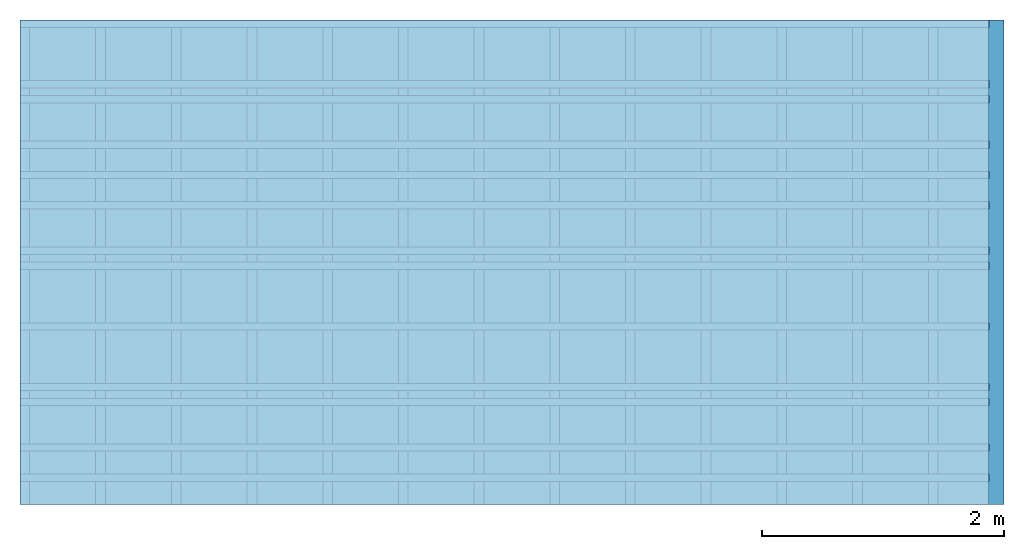
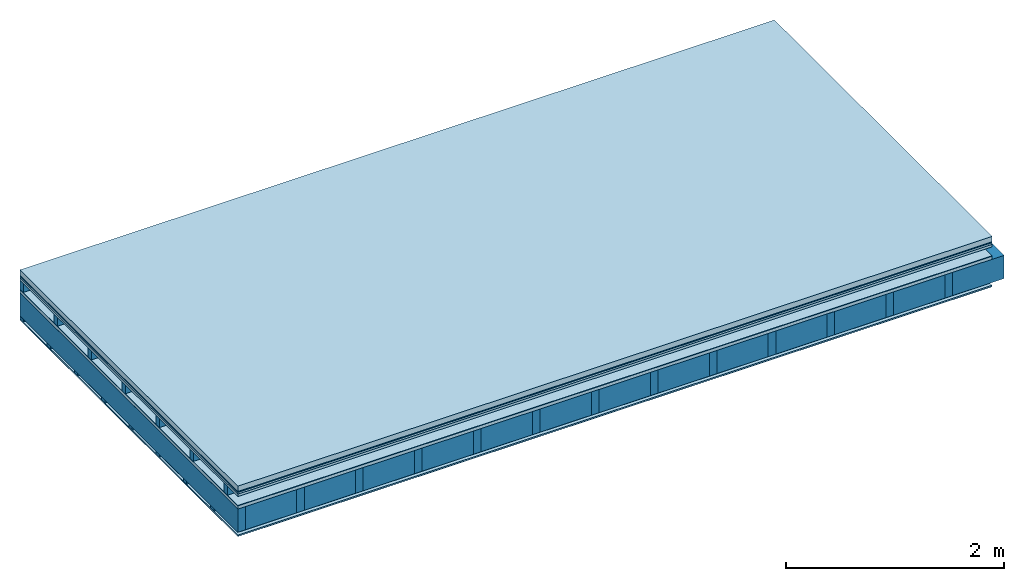
# One storey: 9 plates, 4 members, 1 element without a shape of its own.
"""IFC4 building model written with IfcOpenShell, lengths in metres."""

from ifc_helpers import new_model, si_unit, derived_unit, direction, frame, frame_2d, origin, origin_with_axes, place, context, project, spatial, rectangle, extrude, material, layer, layer_set, type_object, element, aggregate, save


model = new_model("IFC4")

# Units and contexts
plan_context = context("Plan", 3, precision=1e-05, world=origin(), true_north=direction((0.0, 1.0)))
model_context = context("Model", 3, precision=1e-05, world=origin(), true_north=direction((0.0, 1.0)))
ifc_project = project(units=[si_unit("LENGTHUNIT", "METRE"), derived_unit("SOUNDPRESSUREUNIT", [(si_unit("PRESSUREUNIT", "PASCAL", prefix="MICRO"), 0)]), si_unit("ENERGYUNIT", "JOULE", prefix="MEGA"), si_unit("MASSUNIT", "GRAM", prefix="KILO"), derived_unit("THERMALTRANSMITTANCEUNIT", [(si_unit("POWERUNIT", "WATT"), 1), (si_unit("AREAUNIT", "SQUARE_METRE"), -1), (si_unit("THERMODYNAMICTEMPERATUREUNIT", "KELVIN"), -1)]), derived_unit("AREADENSITYUNIT", [(si_unit("MASSUNIT", "GRAM", prefix="KILO"), 1), (si_unit("AREAUNIT", "SQUARE_METRE"), -1)]), derived_unit("USERDEFINED", [(si_unit("ENERGYUNIT", "JOULE", prefix="MEGA"), 1), (si_unit("AREAUNIT", "SQUARE_METRE"), -1)])], contexts=[plan_context, model_context])

# Site, building, storey
site = spatial("IfcSite", under=ifc_project)
building_placement = place(None, origin())
building = spatial("IfcBuilding", under=site, at=building_placement)
storey_placement = place(building_placement, origin())
storey = spatial("IfcBuildingStorey", under=building, at=storey_placement)

# Slab, members, plates
ifc_material_1 = material(Name="clay", Category="02.004")
ifc_layer_1 = layer(ifc_material_1, 0.06, Name="Use and protection layer 2")
ifc_material_2 = material(Name="Protective layer", Category="09.007")
ifc_layer_2 = layer(ifc_material_2, 0.01, Name="Use and protection layer 1")
ifc_material_3 = material(Name="Bituminous", Category="09.003")
ifc_layer_3 = layer(ifc_material_3, 0.02, Name="Seal")
ifc_material_4 = material(Category="07.009")
ifc_layer_4 = layer(ifc_material_4, 0.027, Name="Covering 1st layer")
ifc_layer_5 = layer(None, 0.1, Name="Battens / profiles")
ifc_material_5 = material(Name="Roofing underlay", Category="09.008")
ifc_layer_6 = layer(ifc_material_5, 0.005, Name="Under the roof")
ifc_material_6 = material(Category="10.009")
ifc_layer_7 = layer(ifc_material_6, 0.035, Name="above 2nd layer")
ifc_material_7 = material(Name="no composite action")
ifc_layer_8 = layer(ifc_material_7, 0.0, Name="Bond")
ifc_layer_9 = layer(None, 0.26, Name="Support")
ifc_material_8 = material(Name="of the art")
ifc_layer_10 = layer(ifc_material_8, 0.0, Name="Bond")
ifc_material_9 = material(Name="Vapor barrier polyethylene (PE)", Category="09.002")
ifc_layer_11 = layer(ifc_material_9, 0.001, Name="Vapor barrier")
ifc_layer_12 = layer(None, 0.03, Name="Battens / profiles")
ifc_material_10 = material(Name="DFH2IR Knauf Diamant hard- plasterboard", Category="03.007")
ifc_layer_13 = layer(ifc_material_10, 0.015, Name="Covering below 1st layer")
ifc_material_11 = material(Category="04.001")
ifc_layer_14 = layer(ifc_material_11, 0.003, Name="Surface below")
ifc_layer_set = layer_set([ifc_layer_1, ifc_layer_2, ifc_layer_3, ifc_layer_4, ifc_layer_5, ifc_layer_6, ifc_layer_7, ifc_layer_8, ifc_layer_9, ifc_layer_10, ifc_layer_11, ifc_layer_12, ifc_layer_13, ifc_layer_14])
slab_type = type_object("IfcSlabType", Name="F0118", PredefinedType="NOTDEFINED", material=ifc_layer_set)
slab_placement = place(None, frame((0.0, 0.0, 0.0), z_axis=(0.0, 0.0, -1.0), x_axis=(1.0, 0.0, 0.0)))
slab = element("IfcSlab", 1, at=slab_placement, inside=storey, type_object=slab_type, material=ifc_layer_set, Name="Slab #1")
ifc_material_12 = material()
member_1_placement = place(slab_placement, origin())
member_1 = element("IfcMember", 2, at=member_1_placement, material=ifc_material_12, Name="Battens / profiles", context=plan_context, shape_type="SweptSolid", body=[
    extrude(rectangle(XDim=0.06, YDim=0.1, at=frame_2d((0.03, 0.05), x_axis=(1.0, 0.0))), frame((0.0, 0.0, 0.117), z_axis=(1.0, 0.0, 0.0), x_axis=(0.0, 1.0, 0.0)), (0.0, 0.0, 1.0), 8.0),
    extrude(rectangle(XDim=0.06, YDim=0.1, at=frame_2d((0.03, 0.05), x_axis=(1.0, 0.0))), frame((0.0, 0.625, 0.117), z_axis=(1.0, 0.0, 0.0), x_axis=(0.0, 1.0, 0.0)), (0.0, 0.0, 1.0), 8.0),
    extrude(rectangle(XDim=0.06, YDim=0.1, at=frame_2d((0.03, 0.05), x_axis=(1.0, 0.0))), frame((0.0, 1.25, 0.117), z_axis=(1.0, 0.0, 0.0), x_axis=(0.0, 1.0, 0.0)), (0.0, 0.0, 1.0), 8.0),
    extrude(rectangle(XDim=0.06, YDim=0.1, at=frame_2d((0.03, 0.05), x_axis=(1.0, 0.0))), frame((0.0, 1.875, 0.117), z_axis=(1.0, 0.0, 0.0), x_axis=(0.0, 1.0, 0.0)), (0.0, 0.0, 1.0), 8.0),
    extrude(rectangle(XDim=0.06, YDim=0.1, at=frame_2d((0.03, 0.05), x_axis=(1.0, 0.0))), frame((0.0, 2.5, 0.117), z_axis=(1.0, 0.0, 0.0), x_axis=(0.0, 1.0, 0.0)), (0.0, 0.0, 1.0), 8.0),
    extrude(rectangle(XDim=0.06, YDim=0.1, at=frame_2d((0.03, 0.05), x_axis=(1.0, 0.0))), frame((0.0, 3.125, 0.117), z_axis=(1.0, 0.0, 0.0), x_axis=(0.0, 1.0, 0.0)), (0.0, 0.0, 1.0), 8.0),
    extrude(rectangle(XDim=0.06, YDim=0.1, at=frame_2d((0.03, 0.05), x_axis=(1.0, 0.0))), frame((0.0, 3.75, 0.117), z_axis=(1.0, 0.0, 0.0), x_axis=(0.0, 1.0, 0.0)), (0.0, 0.0, 1.0), 8.0),
])
ifc_material_13 = material()
member_2_placement = place(slab_placement, origin())
member_2 = element("IfcMember", 3, at=member_2_placement, material=ifc_material_13, Name="Support", context=plan_context, shape_type="SweptSolid", body=[
    extrude(rectangle(XDim=0.08, YDim=0.26, at=frame_2d((0.04, 0.13), x_axis=(1.0, 0.0))), frame((0.0, 4.0, 0.257), z_axis=(0.0, -1.0, 0.0), x_axis=(1.0, 0.0, 0.0)), (0.0, 0.0, 1.0), 4.0),
    extrude(rectangle(XDim=0.08, YDim=0.26, at=frame_2d((0.04, 0.13), x_axis=(1.0, 0.0))), frame((0.625, 4.0, 0.257), z_axis=(0.0, -1.0, 0.0), x_axis=(1.0, 0.0, 0.0)), (0.0, 0.0, 1.0), 4.0),
    extrude(rectangle(XDim=0.08, YDim=0.26, at=frame_2d((0.04, 0.13), x_axis=(1.0, 0.0))), frame((1.25, 4.0, 0.257), z_axis=(0.0, -1.0, 0.0), x_axis=(1.0, 0.0, 0.0)), (0.0, 0.0, 1.0), 4.0),
    extrude(rectangle(XDim=0.08, YDim=0.26, at=frame_2d((0.04, 0.13), x_axis=(1.0, 0.0))), frame((1.875, 4.0, 0.257), z_axis=(0.0, -1.0, 0.0), x_axis=(1.0, 0.0, 0.0)), (0.0, 0.0, 1.0), 4.0),
    extrude(rectangle(XDim=0.08, YDim=0.26, at=frame_2d((0.04, 0.13), x_axis=(1.0, 0.0))), frame((2.5, 4.0, 0.257), z_axis=(0.0, -1.0, 0.0), x_axis=(1.0, 0.0, 0.0)), (0.0, 0.0, 1.0), 4.0),
    extrude(rectangle(XDim=0.08, YDim=0.26, at=frame_2d((0.04, 0.13), x_axis=(1.0, 0.0))), frame((3.125, 4.0, 0.257), z_axis=(0.0, -1.0, 0.0), x_axis=(1.0, 0.0, 0.0)), (0.0, 0.0, 1.0), 4.0),
    extrude(rectangle(XDim=0.08, YDim=0.26, at=frame_2d((0.04, 0.13), x_axis=(1.0, 0.0))), frame((3.75, 4.0, 0.257), z_axis=(0.0, -1.0, 0.0), x_axis=(1.0, 0.0, 0.0)), (0.0, 0.0, 1.0), 4.0),
    extrude(rectangle(XDim=0.08, YDim=0.26, at=frame_2d((0.04, 0.13), x_axis=(1.0, 0.0))), frame((4.375, 4.0, 0.257), z_axis=(0.0, -1.0, 0.0), x_axis=(1.0, 0.0, 0.0)), (0.0, 0.0, 1.0), 4.0),
    extrude(rectangle(XDim=0.08, YDim=0.26, at=frame_2d((0.04, 0.13), x_axis=(1.0, 0.0))), frame((5.0, 4.0, 0.257), z_axis=(0.0, -1.0, 0.0), x_axis=(1.0, 0.0, 0.0)), (0.0, 0.0, 1.0), 4.0),
    extrude(rectangle(XDim=0.08, YDim=0.26, at=frame_2d((0.04, 0.13), x_axis=(1.0, 0.0))), frame((5.625, 4.0, 0.257), z_axis=(0.0, -1.0, 0.0), x_axis=(1.0, 0.0, 0.0)), (0.0, 0.0, 1.0), 4.0),
    extrude(rectangle(XDim=0.08, YDim=0.26, at=frame_2d((0.04, 0.13), x_axis=(1.0, 0.0))), frame((6.25, 4.0, 0.257), z_axis=(0.0, -1.0, 0.0), x_axis=(1.0, 0.0, 0.0)), (0.0, 0.0, 1.0), 4.0),
    extrude(rectangle(XDim=0.08, YDim=0.26, at=frame_2d((0.04, 0.13), x_axis=(1.0, 0.0))), frame((6.875, 4.0, 0.257), z_axis=(0.0, -1.0, 0.0), x_axis=(1.0, 0.0, 0.0)), (0.0, 0.0, 1.0), 4.0),
    extrude(rectangle(XDim=0.08, YDim=0.26, at=frame_2d((0.04, 0.13), x_axis=(1.0, 0.0))), frame((7.5, 4.0, 0.257), z_axis=(0.0, -1.0, 0.0), x_axis=(1.0, 0.0, 0.0)), (0.0, 0.0, 1.0), 4.0),
])
ifc_material_14 = material()
member_3_placement = place(slab_placement, origin())
member_3 = element("IfcMember", 4, at=member_3_placement, material=ifc_material_14, Name="Cavity", context=plan_context, shape_type="SweptSolid", body=[
    extrude(rectangle(XDim=0.545, YDim=0.26, at=frame_2d((0.2725, 0.13), x_axis=(1.0, 0.0))), frame((0.08, 4.0, 0.257), z_axis=(0.0, -1.0, 0.0), x_axis=(1.0, 0.0, 0.0)), (0.0, 0.0, 1.0), 4.0),
    extrude(rectangle(XDim=0.545, YDim=0.26, at=frame_2d((0.2725, 0.13), x_axis=(1.0, 0.0))), frame((0.705, 4.0, 0.257), z_axis=(0.0, -1.0, 0.0), x_axis=(1.0, 0.0, 0.0)), (0.0, 0.0, 1.0), 4.0),
    extrude(rectangle(XDim=0.545, YDim=0.26, at=frame_2d((0.2725, 0.13), x_axis=(1.0, 0.0))), frame((1.33, 4.0, 0.257), z_axis=(0.0, -1.0, 0.0), x_axis=(1.0, 0.0, 0.0)), (0.0, 0.0, 1.0), 4.0),
    extrude(rectangle(XDim=0.545, YDim=0.26, at=frame_2d((0.2725, 0.13), x_axis=(1.0, 0.0))), frame((1.955, 4.0, 0.257), z_axis=(0.0, -1.0, 0.0), x_axis=(1.0, 0.0, 0.0)), (0.0, 0.0, 1.0), 4.0),
    extrude(rectangle(XDim=0.545, YDim=0.26, at=frame_2d((0.2725, 0.13), x_axis=(1.0, 0.0))), frame((2.58, 4.0, 0.257), z_axis=(0.0, -1.0, 0.0), x_axis=(1.0, 0.0, 0.0)), (0.0, 0.0, 1.0), 4.0),
    extrude(rectangle(XDim=0.545, YDim=0.26, at=frame_2d((0.2725, 0.13), x_axis=(1.0, 0.0))), frame((3.205, 4.0, 0.257), z_axis=(0.0, -1.0, 0.0), x_axis=(1.0, 0.0, 0.0)), (0.0, 0.0, 1.0), 4.0),
    extrude(rectangle(XDim=0.545, YDim=0.26, at=frame_2d((0.2725, 0.13), x_axis=(1.0, 0.0))), frame((3.83, 4.0, 0.257), z_axis=(0.0, -1.0, 0.0), x_axis=(1.0, 0.0, 0.0)), (0.0, 0.0, 1.0), 4.0),
    extrude(rectangle(XDim=0.545, YDim=0.26, at=frame_2d((0.2725, 0.13), x_axis=(1.0, 0.0))), frame((4.455, 4.0, 0.257), z_axis=(0.0, -1.0, 0.0), x_axis=(1.0, 0.0, 0.0)), (0.0, 0.0, 1.0), 4.0),
    extrude(rectangle(XDim=0.545, YDim=0.26, at=frame_2d((0.2725, 0.13), x_axis=(1.0, 0.0))), frame((5.08, 4.0, 0.257), z_axis=(0.0, -1.0, 0.0), x_axis=(1.0, 0.0, 0.0)), (0.0, 0.0, 1.0), 4.0),
    extrude(rectangle(XDim=0.545, YDim=0.26, at=frame_2d((0.2725, 0.13), x_axis=(1.0, 0.0))), frame((5.705, 4.0, 0.257), z_axis=(0.0, -1.0, 0.0), x_axis=(1.0, 0.0, 0.0)), (0.0, 0.0, 1.0), 4.0),
    extrude(rectangle(XDim=0.545, YDim=0.26, at=frame_2d((0.2725, 0.13), x_axis=(1.0, 0.0))), frame((6.33, 4.0, 0.257), z_axis=(0.0, -1.0, 0.0), x_axis=(1.0, 0.0, 0.0)), (0.0, 0.0, 1.0), 4.0),
    extrude(rectangle(XDim=0.545, YDim=0.26, at=frame_2d((0.2725, 0.13), x_axis=(1.0, 0.0))), frame((6.955, 4.0, 0.257), z_axis=(0.0, -1.0, 0.0), x_axis=(1.0, 0.0, 0.0)), (0.0, 0.0, 1.0), 4.0),
    extrude(rectangle(XDim=0.545, YDim=0.26, at=frame_2d((0.2725, 0.13), x_axis=(1.0, 0.0))), frame((7.58, 4.0, 0.257), z_axis=(0.0, -1.0, 0.0), x_axis=(1.0, 0.0, 0.0)), (0.0, 0.0, 1.0), 4.0),
])
member_4_placement = place(slab_placement, origin())
member_4 = element("IfcMember", 5, at=member_4_placement, material=ifc_material_12, Name="Battens / profiles", context=plan_context, shape_type="SweptSolid", body=[
    extrude(rectangle(XDim=0.06, YDim=0.03, at=frame_2d((0.03, 0.015), x_axis=(1.0, 0.0))), frame((0.0, 0.0, 0.518), z_axis=(1.0, 0.0, 0.0), x_axis=(0.0, 1.0, 0.0)), (0.0, 0.0, 1.0), 8.0),
    extrude(rectangle(XDim=0.06, YDim=0.03, at=frame_2d((0.03, 0.015), x_axis=(1.0, 0.0))), frame((0.0, 0.5, 0.518), z_axis=(1.0, 0.0, 0.0), x_axis=(0.0, 1.0, 0.0)), (0.0, 0.0, 1.0), 8.0),
    extrude(rectangle(XDim=0.06, YDim=0.03, at=frame_2d((0.03, 0.015), x_axis=(1.0, 0.0))), frame((0.0, 1.0, 0.518), z_axis=(1.0, 0.0, 0.0), x_axis=(0.0, 1.0, 0.0)), (0.0, 0.0, 1.0), 8.0),
    extrude(rectangle(XDim=0.06, YDim=0.03, at=frame_2d((0.03, 0.015), x_axis=(1.0, 0.0))), frame((0.0, 1.5, 0.518), z_axis=(1.0, 0.0, 0.0), x_axis=(0.0, 1.0, 0.0)), (0.0, 0.0, 1.0), 8.0),
    extrude(rectangle(XDim=0.06, YDim=0.03, at=frame_2d((0.03, 0.015), x_axis=(1.0, 0.0))), frame((0.0, 2.0, 0.518), z_axis=(1.0, 0.0, 0.0), x_axis=(0.0, 1.0, 0.0)), (0.0, 0.0, 1.0), 8.0),
    extrude(rectangle(XDim=0.06, YDim=0.03, at=frame_2d((0.03, 0.015), x_axis=(1.0, 0.0))), frame((0.0, 2.5, 0.518), z_axis=(1.0, 0.0, 0.0), x_axis=(0.0, 1.0, 0.0)), (0.0, 0.0, 1.0), 8.0),
    extrude(rectangle(XDim=0.06, YDim=0.03, at=frame_2d((0.03, 0.015), x_axis=(1.0, 0.0))), frame((0.0, 3.0, 0.518), z_axis=(1.0, 0.0, 0.0), x_axis=(0.0, 1.0, 0.0)), (0.0, 0.0, 1.0), 8.0),
    extrude(rectangle(XDim=0.06, YDim=0.03, at=frame_2d((0.03, 0.015), x_axis=(1.0, 0.0))), frame((0.0, 3.5, 0.518), z_axis=(1.0, 0.0, 0.0), x_axis=(0.0, 1.0, 0.0)), (0.0, 0.0, 1.0), 8.0),
])
plate_1_placement = place(slab_placement, origin())
plate_1 = element("IfcPlate", 6, at=plate_1_placement, material=ifc_material_1, Name="Use and protection layer 2", context=plan_context, shape_type="SweptSolid", body=[
    extrude(rectangle(XDim=8.0, YDim=4.0, at=frame_2d((4.0, 2.0), x_axis=(1.0, 0.0))), origin_with_axes(), (0.0, 0.0, 1.0), 0.06),
])
plate_2_placement = place(slab_placement, origin())
plate_2 = element("IfcPlate", 7, at=plate_2_placement, material=ifc_material_2, Name="Use and protection layer 1", context=plan_context, shape_type="SweptSolid", body=[
    extrude(rectangle(XDim=8.0, YDim=4.0, at=frame_2d((4.0, 2.0), x_axis=(1.0, 0.0))), frame((0.0, 0.0, 0.06), z_axis=(0.0, 0.0, 1.0), x_axis=(1.0, 0.0, 0.0)), (0.0, 0.0, 1.0), 0.01),
])
plate_3_placement = place(slab_placement, origin())
plate_3 = element("IfcPlate", 8, at=plate_3_placement, material=ifc_material_3, Name="Seal", context=plan_context, shape_type="SweptSolid", body=[
    extrude(rectangle(XDim=8.0, YDim=4.0, at=frame_2d((4.0, 2.0), x_axis=(1.0, 0.0))), frame((0.0, 0.0, 0.07), z_axis=(0.0, 0.0, 1.0), x_axis=(1.0, 0.0, 0.0)), (0.0, 0.0, 1.0), 0.02),
])
plate_4_placement = place(slab_placement, origin())
plate_4 = element("IfcPlate", 9, at=plate_4_placement, material=ifc_material_4, Name="Covering 1st layer", context=plan_context, shape_type="SweptSolid", body=[
    extrude(rectangle(XDim=8.0, YDim=4.0, at=frame_2d((4.0, 2.0), x_axis=(1.0, 0.0))), frame((0.0, 0.0, 0.09), z_axis=(0.0, 0.0, 1.0), x_axis=(1.0, 0.0, 0.0)), (0.0, 0.0, 1.0), 0.027),
])
plate_5_placement = place(slab_placement, origin())
plate_5 = element("IfcPlate", 10, at=plate_5_placement, material=ifc_material_5, Name="Under the roof", context=plan_context, shape_type="SweptSolid", body=[
    extrude(rectangle(XDim=8.0, YDim=4.0, at=frame_2d((4.0, 2.0), x_axis=(1.0, 0.0))), frame((0.0, 0.0, 0.217), z_axis=(0.0, 0.0, 1.0), x_axis=(1.0, 0.0, 0.0)), (0.0, 0.0, 1.0), 0.005),
])
plate_6_placement = place(slab_placement, origin())
plate_6 = element("IfcPlate", 11, at=plate_6_placement, material=ifc_material_6, Name="above 2nd layer", context=plan_context, shape_type="SweptSolid", body=[
    extrude(rectangle(XDim=8.0, YDim=4.0, at=frame_2d((4.0, 2.0), x_axis=(1.0, 0.0))), frame((0.0, 0.0, 0.222), z_axis=(0.0, 0.0, 1.0), x_axis=(1.0, 0.0, 0.0)), (0.0, 0.0, 1.0), 0.035),
])
plate_7_placement = place(slab_placement, origin())
plate_7 = element("IfcPlate", 12, at=plate_7_placement, material=ifc_material_9, Name="Vapor barrier", context=plan_context, shape_type="SweptSolid", body=[
    extrude(rectangle(XDim=8.0, YDim=4.0, at=frame_2d((4.0, 2.0), x_axis=(1.0, 0.0))), frame((0.0, 0.0, 0.517), z_axis=(0.0, 0.0, 1.0), x_axis=(1.0, 0.0, 0.0)), (0.0, 0.0, 1.0), 0.001),
])
plate_8_placement = place(slab_placement, origin())
plate_8 = element("IfcPlate", 13, at=plate_8_placement, material=ifc_material_10, Name="Covering below 1st layer", context=plan_context, shape_type="SweptSolid", body=[
    extrude(rectangle(XDim=8.0, YDim=4.0, at=frame_2d((4.0, 2.0), x_axis=(1.0, 0.0))), frame((0.0, 0.0, 0.548), z_axis=(0.0, 0.0, 1.0), x_axis=(1.0, 0.0, 0.0)), (0.0, 0.0, 1.0), 0.015),
])
plate_9_placement = place(slab_placement, origin())
plate_9 = element("IfcPlate", 14, at=plate_9_placement, material=ifc_material_11, Name="Surface below", context=plan_context, shape_type="SweptSolid", body=[
    extrude(rectangle(XDim=8.0, YDim=4.0, at=frame_2d((4.0, 2.0), x_axis=(1.0, 0.0))), frame((0.0, 0.0, 0.563), z_axis=(0.0, 0.0, 1.0), x_axis=(1.0, 0.0, 0.0)), (0.0, 0.0, 1.0), 0.003),
])
aggregate(slab, [plate_1, plate_2, plate_3, plate_4, member_1, plate_5, plate_6, member_2, member_3, plate_7, member_4, plate_8, plate_9])

save(model, "model.ifc")
